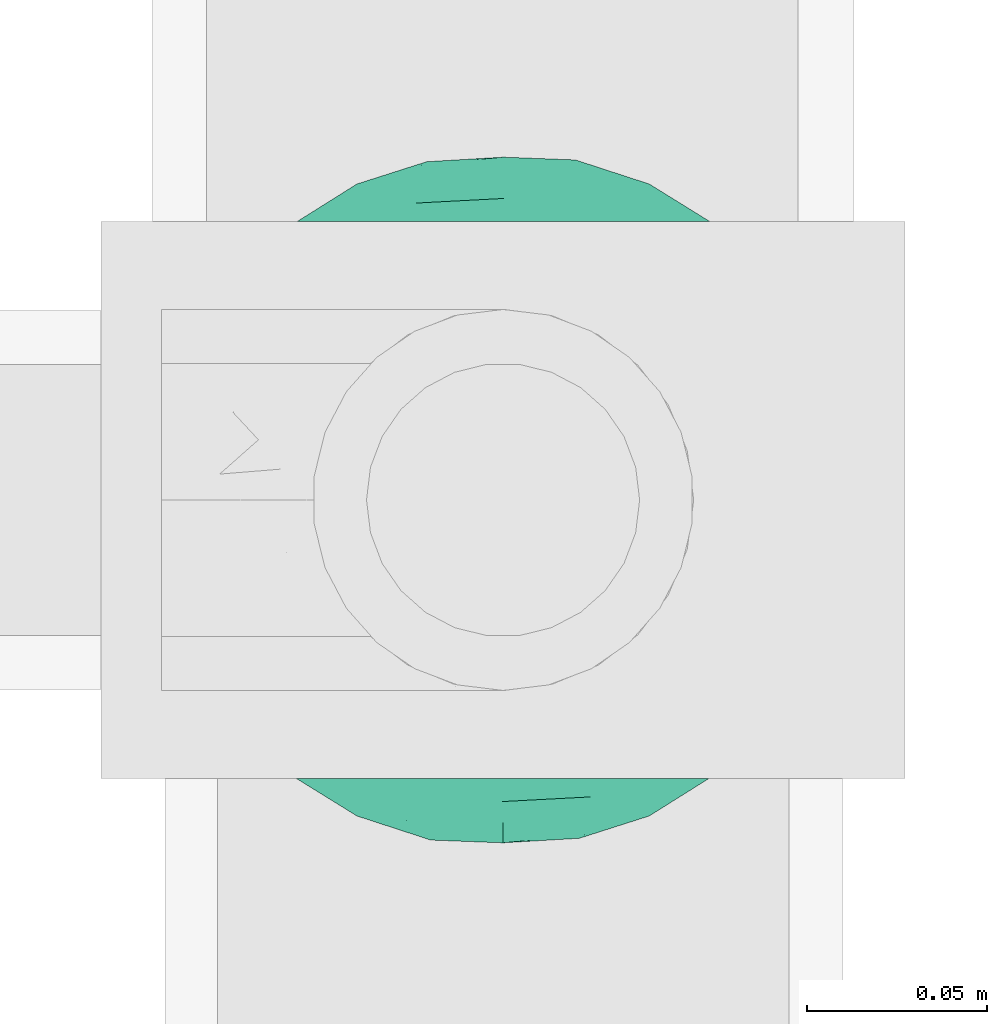
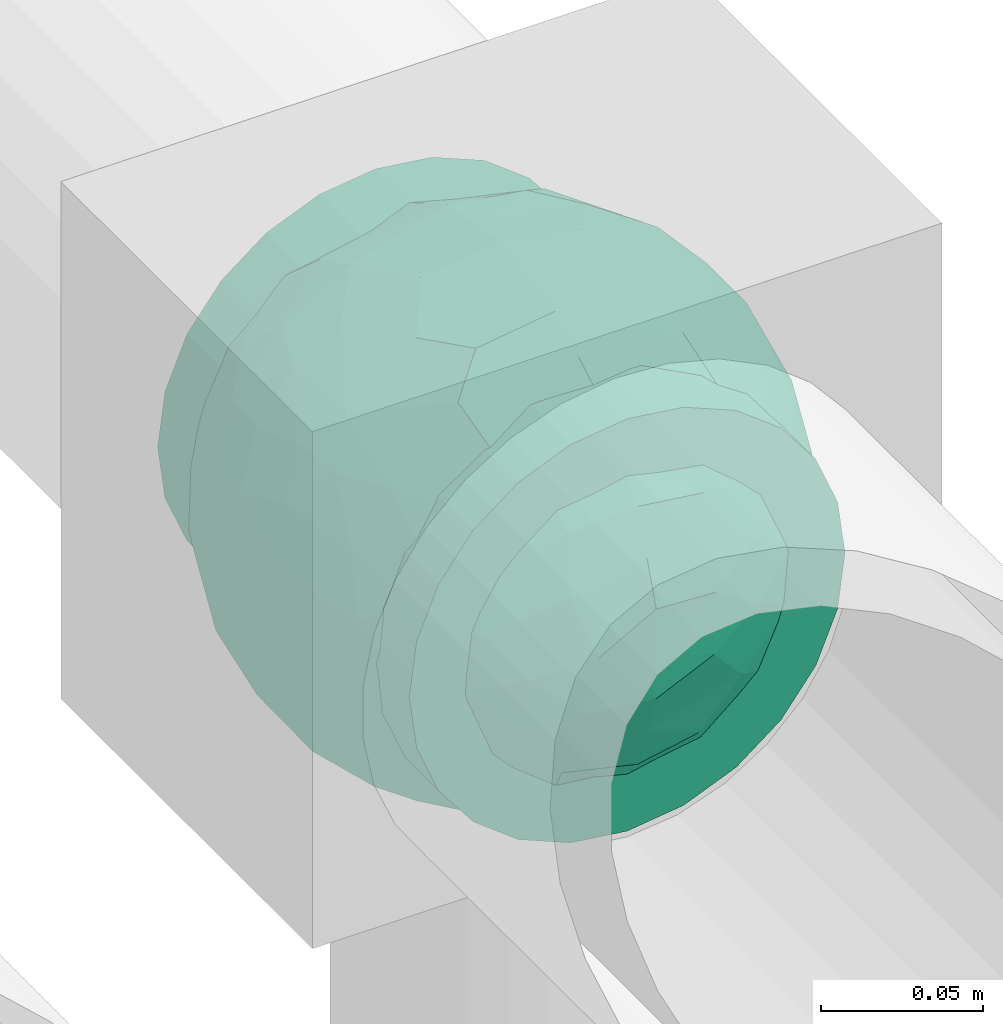
# One storey, part 621 of 827: 1 flow fitting.
"""IFC2X3 building model written with IfcOpenShell, lengths in millimetres."""

from ifc_helpers import new_model, entity, si_unit, converted_unit, derived_unit, direction, frame, origin, place, context, subcontext, project, spatial, faceted_brep, source, transform, mapped, material, material_list, type_object, type_shapes, element, save


model = new_model("IFC2X3")

# Units and contexts
model_context = context("Model", 3, precision=0.01, world=origin(), true_north=direction((6.12303176911189e-17, 1.0)))
body_context = subcontext(model_context, "Body", "Model", "MODEL_VIEW")
ifc_project = project(units=[si_unit("LENGTHUNIT", "METRE", prefix="MILLI"), si_unit("AREAUNIT", "SQUARE_METRE"), si_unit("VOLUMEUNIT", "CUBIC_METRE"), converted_unit("PLANEANGLEUNIT", "DEGREE", entity("IfcRatioMeasure", 0.0174532925199433), si_unit("PLANEANGLEUNIT", "RADIAN"), dimensions=[0, 0, 0, 0, 0, 0, 0]), si_unit("MASSUNIT", "GRAM", prefix="KILO"), derived_unit("MASSDENSITYUNIT", [(si_unit("MASSUNIT", "GRAM", prefix="KILO"), 1), (si_unit("LENGTHUNIT", "METRE"), -3)]), derived_unit("MOMENTOFINERTIAUNIT", [(si_unit("LENGTHUNIT", "METRE"), 4)]), si_unit("TIMEUNIT", "SECOND"), si_unit("FREQUENCYUNIT", "HERTZ"), si_unit("THERMODYNAMICTEMPERATUREUNIT", "DEGREE_CELSIUS"), derived_unit("THERMALTRANSMITTANCEUNIT", [(si_unit("MASSUNIT", "GRAM", prefix="KILO"), 1), (si_unit("THERMODYNAMICTEMPERATUREUNIT", "KELVIN"), -1), (si_unit("TIMEUNIT", "SECOND"), -3)]), derived_unit("VOLUMETRICFLOWRATEUNIT", [(si_unit("LENGTHUNIT", "METRE"), 3), (si_unit("TIMEUNIT", "SECOND"), -1)]), derived_unit("MASSFLOWRATEUNIT", [(si_unit("MASSUNIT", "GRAM", prefix="KILO"), 1), (si_unit("TIMEUNIT", "SECOND"), -1)]), derived_unit("ROTATIONALFREQUENCYUNIT", [(si_unit("TIMEUNIT", "SECOND"), -1)]), si_unit("ELECTRICCURRENTUNIT", "AMPERE"), si_unit("ELECTRICVOLTAGEUNIT", "VOLT"), si_unit("POWERUNIT", "WATT"), si_unit("FORCEUNIT", "NEWTON", prefix="KILO"), si_unit("ILLUMINANCEUNIT", "LUX"), si_unit("LUMINOUSFLUXUNIT", "LUMEN"), si_unit("LUMINOUSINTENSITYUNIT", "CANDELA"), derived_unit("USERDEFINED", [(si_unit("MASSUNIT", "GRAM", prefix="KILO"), -1), (si_unit("LENGTHUNIT", "METRE"), -2), (si_unit("TIMEUNIT", "SECOND"), 3), (si_unit("LUMINOUSFLUXUNIT", "LUMEN"), 1)]), derived_unit("LINEARVELOCITYUNIT", [(si_unit("LENGTHUNIT", "METRE"), 1), (si_unit("TIMEUNIT", "SECOND"), -1)]), si_unit("PRESSUREUNIT", "PASCAL"), derived_unit("USERDEFINED", [(si_unit("LENGTHUNIT", "METRE"), -2), (si_unit("MASSUNIT", "GRAM", prefix="KILO"), 1), (si_unit("TIMEUNIT", "SECOND"), -2)]), derived_unit("LINEARFORCEUNIT", [(si_unit("MASSUNIT", "GRAM", prefix="KILO"), 1), (si_unit("LENGTHUNIT", "METRE"), 1), (si_unit("TIMEUNIT", "SECOND"), -2), (si_unit("LENGTHUNIT", "METRE"), -1)]), derived_unit("PLANARFORCEUNIT", [(si_unit("MASSUNIT", "GRAM", prefix="KILO"), 1), (si_unit("LENGTHUNIT", "METRE"), 1), (si_unit("TIMEUNIT", "SECOND"), -2), (si_unit("LENGTHUNIT", "METRE"), -2)])], contexts=[model_context])

# Site, building, storey
site_placement = place(None, origin())
site = spatial("IfcSite", under=ifc_project, at=site_placement, CompositionType="ELEMENT")
building_placement = place(site_placement, origin())
building = spatial("IfcBuilding", under=site, at=building_placement, CompositionType="ELEMENT")
storey_placement = place(building_placement, frame((0.0, 0.0, 28200.0)))
storey = spatial("IfcBuildingStorey", under=building, at=storey_placement, Name="08", CompositionType="ELEMENT", Elevation=28200.0)

# Flow fitting
ifc_material_1 = material()
ifc_material_2 = material(Name="ADSK_")
ifc_material_list = material_list([ifc_material_1, ifc_material_2])
pipe_fitting_type = type_object("IfcPipeFittingType", Name="ADSK_1", PredefinedType="NOTDEFINED", material=ifc_material_list)
shared_shape = source(origin(), body_context, "Body", "Brep", [
    faceted_brep([(-77.5, 38.75, -67.12), (-77.5, 20.06, -74.86), (-77.5, 0.0, -77.5), (-77.5, -20.06, -74.86), (-77.5, -38.75, -67.12), (-77.5, -54.8, -54.8), (-77.5, -67.12, -38.75), (-77.5, -74.86, -20.06), (-77.5, -76.18, -10.03), (-77.5, -77.5, 0.0), (-77.5, -76.18, 10.03), (-77.5, -74.86, 20.06), (-77.5, -67.12, 38.75), (-77.5, -54.8, 54.8), (-77.5, -38.75, 67.12), (-77.5, -20.06, 74.86), (-77.5, 0.0, 77.5), (-77.5, 20.06, 74.86), (-77.5, 38.75, 67.12), (-77.5, 54.8, 54.8), (-77.5, 67.12, 38.75), (-77.5, 74.86, 20.06), (-77.5, 77.5, 0.0), (-77.5, 74.86, -20.06), (-77.5, 67.12, -38.75), (-77.5, 54.8, -54.8), (77.5, 0.0, -77.5), (77.5, 20.06, -74.86), (77.5, 38.75, -67.12), (77.5, 54.8, -54.8), (77.5, 67.12, -38.75), (77.5, 74.86, -20.06), (77.5, 77.5, 0.0), (77.5, 74.86, 20.06), (77.5, 67.12, 38.75), (77.5, 54.8, 54.8), (77.5, 38.75, 67.12), (77.5, 20.06, 74.86), (77.5, 0.0, 77.5), (77.5, -20.06, 74.86), (77.5, -38.75, 67.12), (77.5, -54.8, 54.8), (77.5, -67.12, 38.75), (77.5, -74.86, 20.06), (77.5, -76.18, 10.03), (77.5, -77.5, 0.0), (77.5, -76.18, -10.03), (77.5, -74.86, -20.06), (77.5, -67.12, -38.75), (77.5, -54.8, -54.8), (77.5, -38.75, -67.12), (77.5, -20.06, -74.86), (32.85, -76.55, 12.09), (35.0, -77.5, 0.0), (-35.0, -77.5, 0.0), (26.77, -74.15, 22.55), (6.15, -69.42, 34.46), (17.58, -71.35, 30.26), (11.87, -70.38, 32.36), (-32.85, -76.55, 12.09), (-33.92, -77.03, 6.04), (-26.78, -74.15, 22.54), (-17.59, -71.35, 30.26), (-11.87, -70.38, 32.36), (-6.16, -69.42, 34.45), (0.0, -69.42, 34.45), (33.92, -77.03, 6.04), (6.15, -69.42, -34.46), (-32.85, -76.55, -12.09), (-33.92, -77.03, -6.04), (17.58, -71.35, -30.26), (11.87, -70.38, -32.36), (32.85, -76.55, -12.09), (26.77, -74.15, -22.55), (33.92, -77.03, -6.04), (-6.16, -69.42, -34.45), (-11.87, -70.38, -32.36), (-17.59, -71.35, -30.26), (0.0, -69.42, -34.45), (-26.78, -74.15, -22.54), (0.0, -82.5, -35.0), (9.06, -82.5, -33.81), (17.5, -82.5, -30.31), (24.75, -82.5, -24.75), (30.31, -82.5, -17.5), (33.81, -82.5, -9.06), (35.0, -82.5, 0.0), (33.81, -82.5, 9.06), (30.31, -82.5, 17.5), (24.75, -82.5, 24.75), (17.5, -82.5, 30.31), (9.06, -82.5, 33.81), (0.0, -82.5, 35.0), (-9.06, -82.5, 33.81), (-17.5, -82.5, 30.31), (-24.75, -82.5, 24.75), (-30.31, -82.5, 17.5), (-33.81, -82.5, 9.06), (-35.0, -82.5, 0.0), (-33.81, -82.5, -9.06), (-30.31, -82.5, -17.5), (-24.75, -82.5, -24.75), (-17.5, -82.5, -30.31), (-9.06, -82.5, -33.81)], [[[0, 1, 2, 3, 4, 5, 6, 7, 8, 9, 10, 11, 12, 13, 14, 15, 16, 17, 18, 19, 20, 21, 22, 23, 24, 25]], [[26, 27, 28, 29, 30, 31, 32, 33, 34, 35, 36, 37, 38, 39, 40, 41, 42, 43, 44, 45, 46, 47, 48, 49, 50, 51]], [[44, 43, 52]], [[53, 45, 44]], [[9, 54, 10]], [[43, 55, 52]], [[42, 41, 56]], [[55, 43, 57]], [[42, 56, 58, 57]], [[41, 13, 56]], [[57, 43, 42]], [[59, 11, 10]], [[10, 54, 60, 59]], [[59, 61, 11]], [[12, 62, 63, 64]], [[12, 11, 62]], [[12, 64, 13]], [[62, 11, 61]], [[13, 64, 65, 56]], [[44, 52, 66, 53]], [[41, 40, 14, 13]], [[16, 15, 39, 38]], [[15, 14, 40, 39]], [[17, 16, 38, 37]], [[34, 33, 21, 20]], [[19, 18, 36, 35]], [[20, 19, 35, 34]], [[37, 36, 18, 17]], [[22, 21, 33, 32]], [[24, 23, 31, 30]], [[23, 22, 32, 31]], [[25, 24, 30, 29]], [[26, 51, 3, 2]], [[1, 0, 28, 27]], [[2, 1, 27, 26]], [[29, 28, 0, 25]], [[4, 3, 51, 50]], [[50, 49, 5, 4]], [[49, 48, 67]], [[8, 68, 69, 54]], [[48, 70, 71, 67]], [[48, 47, 70]], [[49, 67, 5]], [[45, 53, 46]], [[8, 54, 9]], [[72, 73, 47]], [[46, 53, 74, 72]], [[47, 73, 70]], [[6, 75, 76, 77]], [[72, 47, 46]], [[6, 5, 75]], [[77, 7, 6]], [[5, 67, 78, 75]], [[79, 68, 7]], [[68, 8, 7]], [[79, 7, 77]], [[80, 81, 82, 83, 84, 85, 86, 87, 88, 89, 90, 91, 92, 93, 94, 95, 96, 97, 98, 99, 100, 101, 102, 103]], [[98, 97, 60]], [[61, 96, 95]], [[97, 96, 59]], [[95, 94, 62]], [[86, 66, 87]], [[98, 60, 54]], [[59, 96, 61]], [[93, 64, 63]], [[63, 62, 94]], [[62, 61, 95]], [[92, 56, 65, 64]], [[93, 63, 94]], [[58, 56, 91]], [[56, 92, 91]], [[92, 64, 93]], [[55, 89, 88]], [[90, 89, 57]], [[52, 88, 87]], [[90, 58, 91]], [[89, 55, 57]], [[58, 90, 57]], [[87, 66, 52]], [[52, 55, 88]], [[97, 59, 60]], [[66, 86, 53]], [[86, 85, 74]], [[73, 84, 83]], [[85, 84, 72]], [[83, 82, 70]], [[98, 69, 99]], [[86, 74, 53]], [[72, 84, 73]], [[81, 67, 71]], [[71, 70, 82]], [[70, 73, 83]], [[80, 75, 78, 67]], [[81, 71, 82]], [[76, 75, 103]], [[75, 80, 103]], [[80, 67, 81]], [[79, 101, 100]], [[101, 77, 102]], [[100, 99, 68]], [[102, 76, 103]], [[101, 79, 77]], [[76, 102, 77]], [[99, 69, 68]], [[68, 79, 100]], [[85, 72, 74]], [[69, 98, 54]]]),
    faceted_brep([(74.09, -36.62, -50.54), (86.5, -25.35, -35.5), (82.61, -45.18, -22.81), (-16.75, -33.7, -89.27), (0.0, -42.78, -86.92), (-23.87, -49.97, -79.49), (73.94, -14.61, -60.86), (53.84, -28.63, -75.28), (-16.57, 93.95, 0.0), (-18.09, 86.11, -40.53), (-32.84, 86.73, -28.0), (-44.04, -10.15, -85.69), (-19.2, 4.88, -94.83), (-22.92, -15.62, -92.82), (89.65, 32.63, 0.0), (82.61, 44.34, -24.37), (83.9, 48.44, 0.0), (47.7, -82.62, 0.0), (60.26, -69.94, -29.38), (62.27, -74.21, 0.0), (95.4, 0.0, 0.0), (95.4, -16.82, 0.0), (94.13, -8.44, -21.26), (93.14, 13.95, -22.71), (95.4, 16.82, 0.0), (76.54, 8.21, -58.81), (74.09, 36.62, -50.54), (84.96, 22.7, -40.64), (28.25, -36.42, -85.21), (19.67, -61.78, -71.98), (-67.45, 51.53, -46.69), (-45.73, 54.97, -65.36), (-59.68, 42.12, -63.64), (47.7, 82.62, 0.0), (62.27, 74.21, 0.0), (59.48, 63.11, -43.18), (-48.12, -74.69, -38.62), (-33.13, -91.03, 0.0), (-47.7, -82.62, 0.0), (72.35, 57.3, -29.46), (60.01, 43.15, -62.62), (62.52, -52.48, -52.18), (45.73, -54.97, -65.36), (-62.27, -74.21, 0.0), (-73.08, -61.32, 0.0), (-72.41, -59.62, -24.21), (7.26, -81.07, -52.53), (35.35, -68.17, -59.06), (27.87, -86.63, -33.22), (-74.09, -36.62, -50.54), (-84.35, -21.79, -42.37), (-76.59, -6.33, -58.98), (61.55, 0.0, -74.81), (-61.55, 0.0, -74.81), (-79.37, 15.54, -53.33), (-95.4, -16.82, 0.0), (-92.58, -16.52, -23.25), (-89.65, -32.63, 0.0), (63.81, 22.67, -69.28), (-18.69, 68.07, -66.35), (-42.94, 76.94, -40.26), (-74.09, 36.62, -50.54), (-43.64, 36.19, -78.55), (-65.1, 21.71, -68.38), (44.46, 15.06, -84.74), (-65.04, -21.76, -68.42), (-94.63, 4.93, -20.13), (-87.93, 0.0, -40.67), (-89.65, 32.63, 0.0), (-89.27, 26.35, -26.85), (27.96, 84.78, -37.61), (7.26, 81.07, -52.53), (1.19, 92.73, -28.0), (3.41, -92.84, -27.46), (-8.28, -95.41, 0.0), (-11.9, -93.14, -23.83), (73.08, 61.32, 0.0), (87.93, 0.0, -40.67), (73.08, -61.32, 0.0), (83.9, -48.44, 0.0), (-73.08, 61.32, 0.0), (-82.24, 45.34, -23.77), (-83.9, 48.44, 0.0), (-63.57, -59.47, -42.5), (-45.73, -54.97, -65.36), (-82.58, -43.28, -26.32), (29.11, 48.1, -78.89), (45.73, 54.97, -65.36), (44.58, 36.0, -78.11), (-61.2, 65.56, -36.61), (-6.93, -65.5, -71.03), (30.56, -5.14, -91.79), (9.54, -19.86, -94.34), (0.0, 12.89, -96.01), (47.81, -10.83, -83.56), (89.65, -32.63, 0.0), (44.95, 76.64, -38.61), (33.13, 91.03, 0.0), (28.53, 69.09, -61.62), (-51.45, 14.65, -80.76), (22.17, 26.71, -90.44), (33.13, -91.03, 0.0), (44.95, -76.64, -38.61), (72.35, -57.3, -29.46), (16.57, -93.95, 0.0), (-15.25, 22.47, -92.99), (2.72, 32.92, -91.07), (8.92, 50.75, -82.03), (9.42, 67.57, -68.78), (16.57, 93.95, 0.0), (-5.45, -87.35, -41.54), (8.28, -95.41, 0.0), (0.0, -96.88, 0.0), (-24.34, -90.45, -24.71), (-25.14, -82.23, -44.62), (-16.57, -93.95, 0.0), (-9.92, -78.26, -56.23), (-30.26, -67.58, -62.46), (-40.87, -32.58, -81.57), (-34.66, 17.97, -88.66), (-59.69, -42.16, -63.59), (-16.8, 39.61, -86.8), (-28.19, 53.95, -75.36), (-10.32, 55.25, -78.9), (-57.91, -73.21, -25.92), (-83.9, -48.44, 0.0), (-95.4, 0.0, 0.0), (-95.4, 16.82, 0.0), (-72.43, 58.81, -26.08), (-62.27, 74.21, 0.0), (-47.7, 82.62, 0.0), (-33.13, 91.03, 0.0), (0.0, 96.87, 0.0), (-74.09, -36.62, 50.54), (-86.5, -25.35, 35.5), (-82.61, -45.18, 22.81), (16.75, -33.7, 89.27), (0.0, -42.78, 86.92), (23.87, -49.97, 79.49), (-73.94, -14.61, 60.86), (-53.84, -28.63, 75.28), (18.09, 86.11, 40.53), (32.84, 86.73, 28.0), (44.04, -10.15, 85.69), (19.2, 4.88, 94.83), (22.92, -15.62, 92.82), (-82.61, 44.34, 24.37), (-60.26, -69.94, 29.38), (-94.13, -8.44, 21.26), (-93.14, 13.95, 22.71), (-76.54, 8.21, 58.81), (-74.09, 36.62, 50.54), (-84.96, 22.7, 40.64), (-28.25, -36.42, 85.21), (-19.67, -61.78, 71.98), (67.45, 51.53, 46.69), (45.73, 54.97, 65.36), (59.68, 42.12, 63.64), (-28.53, 69.09, 61.62), (-45.73, 54.97, 65.36), (-29.11, 48.1, 78.89), (48.12, -74.69, 38.62), (-59.48, 63.11, 43.18), (-72.35, 57.3, 29.46), (-60.01, 43.15, 62.62), (-35.35, -68.17, 59.06), (-7.26, -81.07, 52.53), (72.41, -59.62, 24.21), (-3.41, -92.84, 27.46), (74.09, -36.62, 50.54), (84.35, -21.79, 42.37), (76.59, -6.33, 58.98), (-61.55, 0.0, 74.81), (61.55, 0.0, 74.81), (79.37, 15.54, 53.33), (92.58, -16.52, 23.25), (-63.81, 22.67, 69.28), (18.69, 68.07, 66.35), (42.94, 76.94, 40.26), (74.09, 36.62, 50.54), (43.64, 36.19, 78.55), (65.1, 21.71, 68.38), (-44.46, 15.06, 84.74), (65.04, -21.76, 68.42), (94.63, 4.93, 20.13), (87.93, 0.0, 40.67), (89.27, 26.35, 26.85), (-27.96, 84.78, 37.61), (-7.26, 81.07, 52.53), (-1.19, 92.73, 28.0), (11.9, -93.14, 23.83), (-87.93, 0.0, 40.67), (82.24, 45.34, 23.77), (63.57, -59.47, 42.5), (45.73, -54.97, 65.36), (82.58, -43.28, 26.32), (-44.58, 36.0, 78.11), (61.2, 65.56, 36.61), (25.14, -82.23, 44.62), (5.45, -87.35, 41.54), (24.34, -90.45, 24.71), (6.93, -65.5, 71.03), (-30.56, -5.14, 91.79), (-9.54, -19.86, 94.34), (0.0, 12.89, 96.01), (-47.81, -10.83, 83.56), (-44.95, 76.64, 38.61), (51.45, 14.65, 80.76), (-62.52, -52.48, 52.18), (-45.73, -54.97, 65.36), (-22.17, 26.71, 90.44), (-44.95, -76.64, 38.61), (-72.35, -57.3, 29.46), (-27.87, -86.63, 33.22), (15.25, 22.47, 92.99), (-2.72, 32.92, 91.07), (-8.92, 50.75, 82.03), (-9.42, 67.57, 68.78), (9.92, -78.26, 56.23), (30.26, -67.58, 62.46), (40.87, -32.58, 81.57), (34.66, 17.97, 88.66), (59.69, -42.16, 63.59), (16.8, 39.61, 86.8), (28.19, 53.95, 75.36), (10.32, 55.25, 78.9), (57.91, -73.21, 25.92), (72.43, 58.81, 26.08)], [[[0, 1, 2]], [[3, 4, 5]], [[6, 0, 7]], [[8, 9, 10]], [[11, 12, 13]], [[14, 15, 16]], [[17, 18, 19]], [[20, 21, 22]], [[23, 24, 20]], [[25, 26, 27]], [[4, 28, 29]], [[30, 31, 32]], [[33, 34, 35]], [[36, 37, 38]], [[35, 39, 40]], [[41, 18, 42]], [[43, 44, 45]], [[46, 47, 48]], [[49, 50, 51]], [[52, 25, 6]], [[53, 51, 54]], [[55, 56, 57]], [[26, 25, 58]], [[59, 31, 60]], [[32, 61, 30]], [[62, 63, 32]], [[52, 64, 58]], [[51, 65, 49]], [[56, 66, 67]], [[66, 68, 69]], [[70, 71, 72]], [[73, 74, 75]], [[6, 7, 52]], [[20, 22, 23]], [[76, 39, 34]], [[15, 26, 39]], [[1, 77, 22]], [[78, 2, 79]], [[61, 54, 69]], [[80, 81, 82]], [[36, 83, 84]], [[85, 56, 50]], [[86, 87, 88]], [[60, 31, 89]], [[48, 73, 46]], [[4, 29, 90]], [[91, 92, 93]], [[7, 94, 52]], [[77, 23, 22]], [[95, 79, 2]], [[0, 6, 1]], [[1, 22, 95]], [[1, 95, 2]], [[27, 23, 77]], [[15, 14, 23]], [[25, 27, 77]], [[15, 76, 16]], [[40, 39, 26]], [[39, 76, 15]], [[96, 97, 33]], [[70, 98, 71]], [[39, 35, 34]], [[87, 86, 98]], [[77, 1, 6]], [[25, 52, 58]], [[62, 99, 63]], [[26, 15, 27]], [[6, 25, 77]], [[0, 41, 7]], [[42, 28, 7]], [[92, 91, 28]], [[94, 28, 91]], [[88, 87, 40]], [[52, 94, 64]], [[40, 26, 58]], [[100, 91, 93]], [[88, 40, 58]], [[22, 21, 95]], [[101, 102, 17]], [[103, 78, 19]], [[41, 0, 103]], [[18, 102, 42]], [[101, 48, 102]], [[101, 104, 48]], [[29, 28, 42]], [[28, 4, 92]], [[102, 47, 42]], [[90, 29, 46]], [[88, 58, 64]], [[40, 87, 35]], [[87, 96, 35]], [[33, 35, 96]], [[100, 64, 91]], [[88, 64, 100]], [[12, 105, 93]], [[98, 96, 87]], [[106, 100, 93]], [[86, 100, 107]], [[100, 86, 88]], [[98, 108, 71]], [[108, 86, 107]], [[109, 70, 72]], [[70, 109, 97]], [[96, 98, 70]], [[97, 96, 70]], [[78, 103, 2]], [[0, 2, 103]], [[41, 103, 18]], [[7, 41, 42]], [[19, 18, 103]], [[102, 18, 17]], [[75, 110, 73]], [[73, 104, 111, 112]], [[113, 114, 110]], [[115, 75, 74]], [[36, 114, 37]], [[90, 5, 4]], [[73, 48, 104]], [[47, 46, 29]], [[46, 116, 90]], [[5, 117, 84]], [[90, 116, 117]], [[118, 13, 3]], [[118, 5, 84]], [[11, 119, 12]], [[65, 120, 49]], [[11, 13, 118]], [[63, 53, 54]], [[121, 122, 123]], [[90, 117, 5]], [[49, 120, 83]], [[117, 36, 84]], [[36, 117, 114]], [[43, 45, 124]], [[38, 124, 36]], [[83, 124, 45]], [[85, 125, 57]], [[125, 85, 44]], [[45, 49, 83]], [[66, 55, 126, 127]], [[57, 56, 85]], [[56, 67, 50]], [[51, 50, 67]], [[85, 50, 49]], [[54, 51, 67]], [[51, 53, 65]], [[69, 54, 67]], [[54, 61, 63]], [[69, 67, 66]], [[128, 129, 89]], [[11, 65, 53]], [[120, 118, 84]], [[32, 63, 61]], [[99, 53, 63]], [[118, 120, 65]], [[83, 120, 84]], [[129, 128, 80]], [[62, 32, 31]], [[60, 130, 131]], [[130, 60, 89]], [[9, 71, 59]], [[10, 60, 131]], [[108, 59, 71]], [[71, 9, 72]], [[62, 121, 119]], [[122, 59, 123]], [[62, 119, 99]], [[62, 31, 122]], [[106, 107, 100]], [[44, 85, 45]], [[49, 45, 85]], [[55, 66, 56]], [[62, 122, 121]], [[89, 129, 130]], [[65, 11, 118]], [[11, 53, 99]], [[80, 128, 81]], [[30, 128, 89]], [[81, 61, 69]], [[61, 81, 128]], [[82, 81, 69]], [[10, 59, 60]], [[72, 8, 132]], [[8, 72, 9]], [[109, 72, 132]], [[3, 92, 4]], [[92, 13, 12]], [[23, 27, 15]], [[14, 24, 23]], [[11, 99, 119]], [[128, 30, 61]], [[31, 30, 89]], [[28, 94, 7]], [[64, 94, 91]], [[48, 47, 102]], [[29, 42, 47]], [[105, 106, 93]], [[123, 106, 121]], [[86, 108, 98]], [[108, 107, 123]], [[73, 112, 74]], [[113, 75, 115]], [[114, 116, 110]], [[115, 37, 113]], [[37, 114, 113]], [[46, 73, 110]], [[117, 116, 114]], [[110, 75, 113]], [[46, 110, 116]], [[118, 3, 5]], [[92, 3, 13]], [[105, 119, 121]], [[92, 12, 93]], [[119, 105, 12]], [[106, 105, 121]], [[43, 124, 38]], [[83, 36, 124]], [[68, 66, 127]], [[68, 82, 69]], [[31, 59, 122]], [[108, 123, 59]], [[106, 123, 107]], [[8, 10, 131]], [[59, 10, 9]], [[133, 134, 135]], [[136, 137, 138]], [[139, 133, 140]], [[109, 141, 142]], [[143, 144, 145]], [[68, 146, 82]], [[38, 147, 43]], [[148, 126, 55]], [[149, 127, 126]], [[150, 151, 152]], [[137, 153, 154]], [[155, 156, 157]], [[158, 159, 160]], [[161, 101, 17]], [[162, 163, 164]], [[154, 165, 166]], [[19, 78, 167]], [[168, 115, 74, 112]], [[169, 170, 171]], [[172, 150, 139]], [[173, 171, 174]], [[21, 175, 95]], [[151, 150, 176]], [[177, 156, 178]], [[157, 179, 155]], [[180, 181, 157]], [[172, 182, 176]], [[171, 183, 169]], [[175, 184, 185]], [[186, 24, 14, 16]], [[187, 188, 189]], [[168, 111, 190]], [[139, 140, 172]], [[126, 148, 149]], [[80, 163, 129]], [[146, 151, 163]], [[134, 191, 148]], [[44, 135, 125]], [[179, 174, 186]], [[76, 192, 16]], [[161, 193, 194]], [[195, 175, 170]], [[160, 159, 196]], [[178, 156, 197]], [[198, 199, 200]], [[137, 154, 201]], [[202, 203, 204]], [[140, 205, 172]], [[134, 133, 139]], [[125, 135, 57]], [[148, 191, 149]], [[134, 148, 57]], [[134, 57, 135]], [[152, 149, 191]], [[146, 68, 149]], [[150, 152, 191]], [[146, 80, 82]], [[164, 163, 151]], [[163, 80, 146]], [[162, 130, 129]], [[130, 206, 131]], [[163, 162, 129]], [[158, 188, 187]], [[191, 134, 139]], [[150, 172, 176]], [[180, 207, 181]], [[151, 146, 152]], [[139, 150, 191]], [[133, 208, 140]], [[209, 153, 140]], [[203, 202, 153]], [[205, 153, 202]], [[196, 159, 164]], [[172, 205, 182]], [[164, 151, 176]], [[210, 202, 204]], [[196, 164, 176]], [[148, 55, 57]], [[38, 37, 211]], [[212, 44, 43]], [[208, 133, 212]], [[147, 211, 209]], [[165, 213, 166]], [[209, 208, 147]], [[154, 153, 209]], [[153, 137, 203]], [[211, 165, 209]], [[201, 154, 166]], [[196, 176, 182]], [[164, 159, 162]], [[159, 206, 162]], [[130, 162, 206]], [[210, 182, 202]], [[196, 182, 210]], [[144, 214, 204]], [[158, 206, 159]], [[215, 210, 204]], [[160, 210, 216]], [[210, 160, 196]], [[158, 217, 188]], [[217, 160, 216]], [[8, 187, 189]], [[187, 8, 131]], [[206, 158, 187]], [[131, 206, 187]], [[44, 212, 135]], [[133, 135, 212]], [[208, 212, 147]], [[140, 208, 209]], [[43, 147, 212]], [[211, 147, 38]], [[199, 168, 190]], [[213, 115, 168]], [[213, 168, 166]], [[104, 190, 111]], [[161, 198, 101]], [[201, 138, 137]], [[37, 115, 213]], [[211, 37, 213]], [[166, 218, 201]], [[138, 219, 194]], [[201, 218, 219]], [[220, 145, 136]], [[220, 138, 194]], [[143, 221, 144]], [[183, 222, 169]], [[143, 145, 220]], [[181, 173, 174]], [[223, 224, 225]], [[201, 219, 138]], [[169, 222, 193]], [[219, 161, 194]], [[161, 219, 198]], [[19, 167, 226]], [[17, 226, 161]], [[193, 226, 167]], [[195, 79, 95]], [[79, 195, 78]], [[167, 169, 193]], [[184, 21, 20, 24]], [[95, 175, 195]], [[175, 185, 170]], [[171, 170, 185]], [[195, 170, 169]], [[174, 171, 185]], [[171, 173, 183]], [[186, 174, 185]], [[174, 179, 181]], [[186, 185, 184]], [[227, 34, 197]], [[143, 183, 173]], [[222, 220, 194]], [[157, 181, 179]], [[207, 173, 181]], [[220, 222, 183]], [[193, 222, 194]], [[34, 227, 76]], [[180, 157, 156]], [[178, 33, 97]], [[33, 178, 197]], [[141, 188, 177]], [[142, 178, 97]], [[217, 177, 188]], [[188, 141, 189]], [[180, 223, 221]], [[224, 177, 225]], [[180, 221, 207]], [[180, 156, 224]], [[215, 216, 210]], [[78, 195, 167]], [[169, 167, 195]], [[21, 184, 175]], [[186, 184, 24]], [[197, 34, 33]], [[183, 143, 220]], [[143, 173, 207]], [[76, 227, 192]], [[155, 227, 197]], [[192, 179, 186]], [[179, 192, 227]], [[16, 192, 186]], [[142, 177, 178]], [[189, 109, 132]], [[109, 189, 141]], [[8, 189, 132]], [[136, 203, 137]], [[203, 145, 144]], [[149, 152, 146]], [[68, 127, 149]], [[143, 207, 221]], [[227, 155, 179]], [[156, 155, 197]], [[153, 205, 140]], [[182, 205, 202]], [[213, 165, 211]], [[154, 209, 165]], [[214, 215, 204]], [[225, 215, 223]], [[160, 217, 158]], [[217, 216, 225]], [[168, 112, 111]], [[200, 190, 104]], [[198, 218, 199]], [[104, 101, 200]], [[101, 198, 200]], [[166, 168, 199]], [[219, 218, 198]], [[199, 190, 200]], [[166, 199, 218]], [[220, 136, 138]], [[203, 136, 145]], [[214, 221, 223]], [[203, 144, 204]], [[221, 214, 144]], [[215, 214, 223]], [[19, 226, 17]], [[193, 161, 226]], [[180, 224, 223]], [[156, 177, 224]], [[217, 225, 177]], [[215, 225, 216]], [[109, 142, 97]], [[177, 142, 141]]]),
])
type_shapes(pipe_fitting_type, [shared_shape])
flow_fitting_placement = place(storey_placement, frame((38048.3, 11730.2, 3000.0), z_axis=(1.0, 0.0, 0.0), x_axis=(0.0, 1.0, 0.0)))
element("IfcFlowFitting", 1, at=flow_fitting_placement, inside=storey, type_object=pipe_fitting_type, material=ifc_material_list, Name="ADSK_1", ObjectType="ADSK_1", context=body_context, shape_type="MappedRepresentation", body=[
    mapped(shared_shape, transform((0.0, 0.0, 0.0), scale=1.0)),
])

save(model, "model.ifc")
